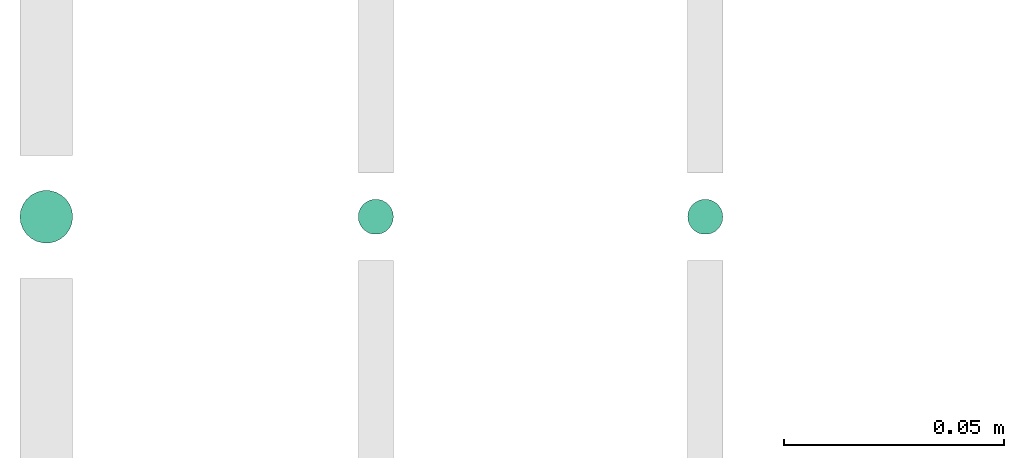
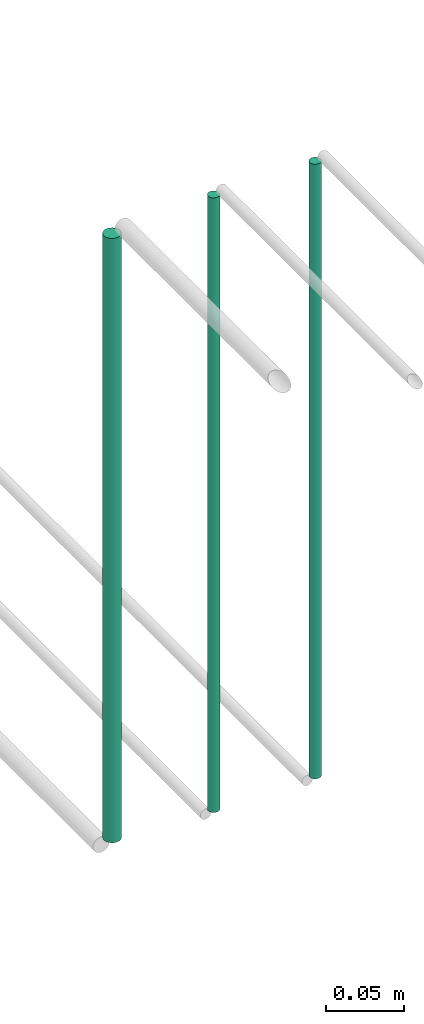
# One storey, part 27 of 65: 3 flow segments.
"""IFC2X3 building model written with IfcOpenShell, lengths in millimetres."""

from ifc_helpers import new_model, entity, si_unit, converted_unit, derived_unit, direction, frame, origin, origin_2d_with_axis, place, context, subcontext, project, spatial, circle, extrude, type_object, element, save


model = new_model("IFC2X3")

# Units and contexts
model_context = context("Model", 3, precision=0.01, world=origin(), true_north=direction((6.12303176911189e-17, 1.0)))
body_context = subcontext(model_context, "Body", "Model", "MODEL_VIEW")
ifc_project = project(units=[si_unit("LENGTHUNIT", "METRE", prefix="MILLI"), si_unit("AREAUNIT", "SQUARE_METRE"), si_unit("VOLUMEUNIT", "CUBIC_METRE"), converted_unit("PLANEANGLEUNIT", "DEGREE", entity("IfcRatioMeasure", 0.0174532925199433), si_unit("PLANEANGLEUNIT", "RADIAN"), dimensions=[0, 0, 0, 0, 0, 0, 0]), si_unit("MASSUNIT", "GRAM", prefix="KILO"), derived_unit("MASSDENSITYUNIT", [(si_unit("MASSUNIT", "GRAM", prefix="KILO"), 1), (si_unit("LENGTHUNIT", "METRE"), -3)]), derived_unit("MOMENTOFINERTIAUNIT", [(si_unit("LENGTHUNIT", "METRE"), 4)]), si_unit("TIMEUNIT", "SECOND"), si_unit("FREQUENCYUNIT", "HERTZ"), si_unit("THERMODYNAMICTEMPERATUREUNIT", "DEGREE_CELSIUS"), derived_unit("THERMALTRANSMITTANCEUNIT", [(si_unit("MASSUNIT", "GRAM", prefix="KILO"), 1), (si_unit("THERMODYNAMICTEMPERATUREUNIT", "KELVIN"), -1), (si_unit("TIMEUNIT", "SECOND"), -3)]), derived_unit("VOLUMETRICFLOWRATEUNIT", [(si_unit("LENGTHUNIT", "METRE"), 3), (si_unit("TIMEUNIT", "SECOND"), -1)]), derived_unit("MASSFLOWRATEUNIT", [(si_unit("MASSUNIT", "GRAM", prefix="KILO"), 1), (si_unit("TIMEUNIT", "SECOND"), -1)]), derived_unit("ROTATIONALFREQUENCYUNIT", [(si_unit("TIMEUNIT", "SECOND"), -1)]), si_unit("ELECTRICCURRENTUNIT", "AMPERE"), si_unit("ELECTRICVOLTAGEUNIT", "VOLT"), si_unit("POWERUNIT", "WATT"), si_unit("FORCEUNIT", "NEWTON", prefix="KILO"), si_unit("ILLUMINANCEUNIT", "LUX"), si_unit("LUMINOUSFLUXUNIT", "LUMEN"), si_unit("LUMINOUSINTENSITYUNIT", "CANDELA"), derived_unit("USERDEFINED", [(si_unit("MASSUNIT", "GRAM", prefix="KILO"), -1), (si_unit("LENGTHUNIT", "METRE"), -2), (si_unit("TIMEUNIT", "SECOND"), 3), (si_unit("LUMINOUSFLUXUNIT", "LUMEN"), 1)]), derived_unit("LINEARVELOCITYUNIT", [(si_unit("LENGTHUNIT", "METRE"), 1), (si_unit("TIMEUNIT", "SECOND"), -1)]), si_unit("PRESSUREUNIT", "PASCAL"), derived_unit("USERDEFINED", [(si_unit("LENGTHUNIT", "METRE"), -2), (si_unit("MASSUNIT", "GRAM", prefix="KILO"), 1), (si_unit("TIMEUNIT", "SECOND"), -2)]), derived_unit("LINEARFORCEUNIT", [(si_unit("MASSUNIT", "GRAM", prefix="KILO"), 1), (si_unit("LENGTHUNIT", "METRE"), 1), (si_unit("TIMEUNIT", "SECOND"), -2), (si_unit("LENGTHUNIT", "METRE"), -1)]), derived_unit("PLANARFORCEUNIT", [(si_unit("MASSUNIT", "GRAM", prefix="KILO"), 1), (si_unit("LENGTHUNIT", "METRE"), 1), (si_unit("TIMEUNIT", "SECOND"), -2), (si_unit("LENGTHUNIT", "METRE"), -2)])], contexts=[model_context])

# Site, building, storey
site_placement = place(None, frame((0.0, -0.00077364408347762, 0.0)))
site = spatial("IfcSite", under=ifc_project, at=site_placement, CompositionType="ELEMENT")
building_placement = place(site_placement, origin())
building = spatial("IfcBuilding", under=site, at=building_placement, CompositionType="ELEMENT")
storey_placement = place(building_placement, frame((0.0, 0.0, 19800.0)))
storey = spatial("IfcBuildingStorey", under=building, at=storey_placement, CompositionType="ELEMENT", Elevation=19800.0)

# Flow segments
pipe_segment_type = type_object("IfcPipeSegmentType", PredefinedType="NOTDEFINED")
flow_segment_1_placement = place(storey_placement, frame((16322.4047325917, 4278.33676731978, 2564.0)))
element("IfcFlowSegment", 1, at=flow_segment_1_placement, inside=storey, type_object=pipe_segment_type, context=body_context, shape_type="SweptSolid", body=[
    extrude(circle(Radius=6.0, at=origin_2d_with_axis()), frame((7.5952722359167, 7.59527223591616, 0.0)), (0.0, 0.0, 1.0), 472.000000000001),
])
flow_segment_2_placement = place(storey_placement, frame((16399.4047325915, 4280.33676731978, 2560.0)))
element("IfcFlowSegment", 2, at=flow_segment_2_placement, inside=storey, type_object=pipe_segment_type, context=body_context, shape_type="SweptSolid", body=[
    extrude(circle(Radius=4.0, at=origin_2d_with_axis()), frame((5.59527223591499, 5.59527223591607, 0.0)), (0.0, 0.0, 1.0), 479.999999999995),
])
flow_segment_3_placement = place(storey_placement, frame((16474.4047325923, 4280.33672618512, 2560.0)))
element("IfcFlowSegment", 3, at=flow_segment_3_placement, inside=storey, type_object=pipe_segment_type, context=body_context, shape_type="SweptSolid", body=[
    extrude(circle(Radius=4.0, at=origin_2d_with_axis()), frame((5.59527223591499, 5.59535450196374, 6.85550185153261e-07)), (0.0, 0.0, 1.0), 479.99999852884),
])

save(model, "model.ifc")
